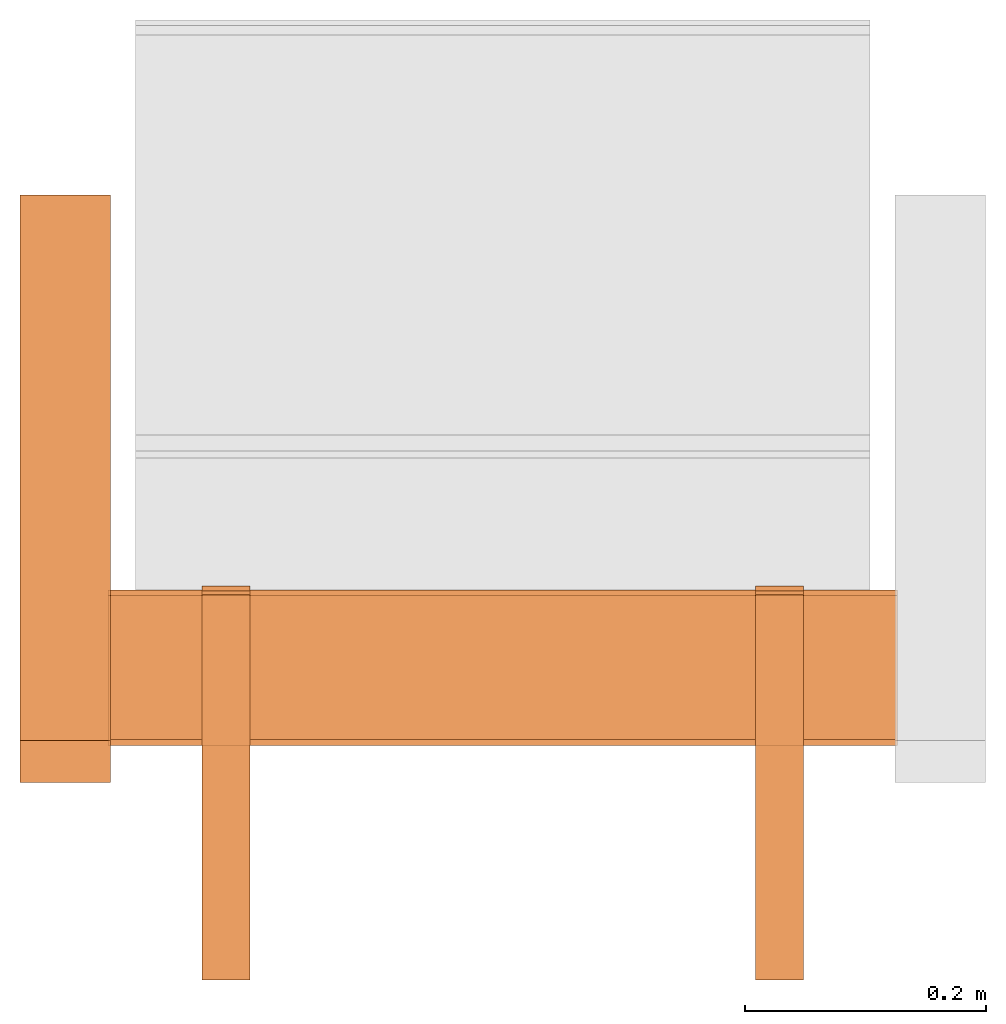
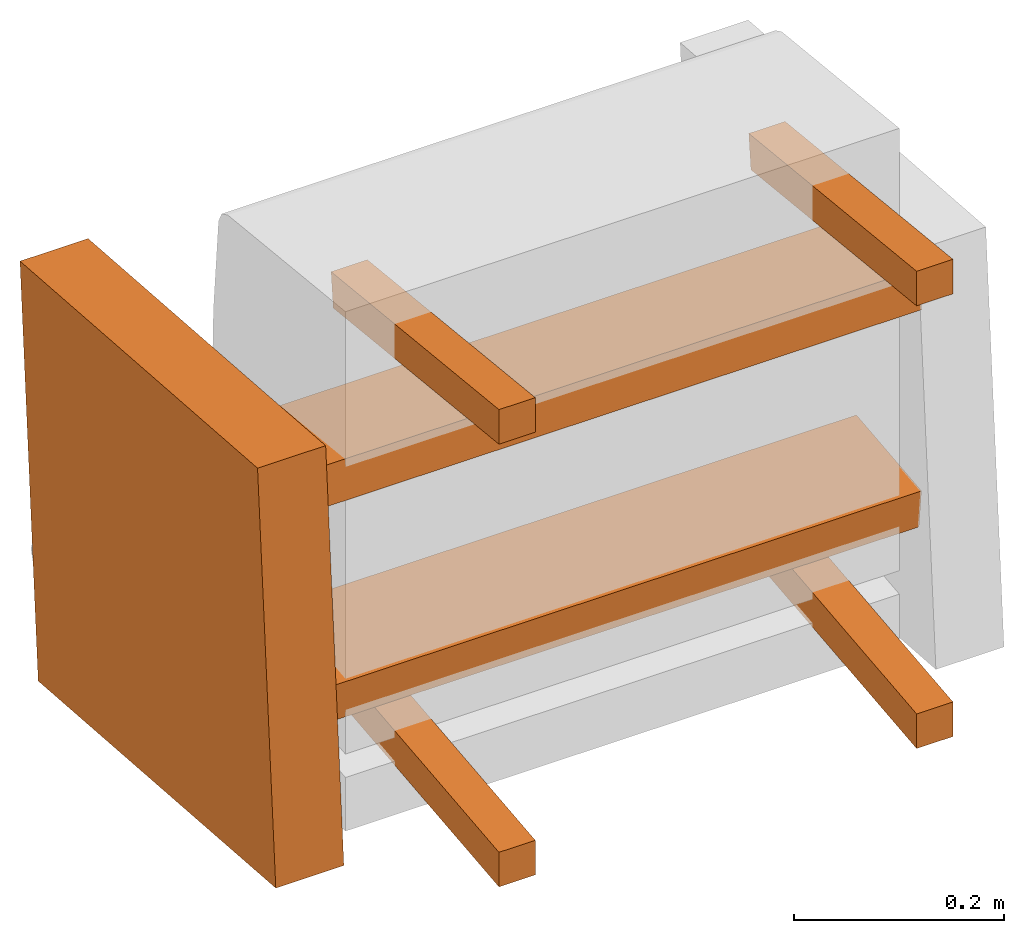
# One storey, part 2 of 2: 7 proxies, 1 element without a shape of its own.
"""IFC2X3 building model written with IfcOpenShell, lengths in metres."""

from ifc_helpers import new_model, si_unit, direction, origin_with_axes, place, context, project, spatial, faceted_brep, source, transform, mapped, element, aggregate, save


model = new_model("IFC2X3")

# Units and contexts
model_context = context("Model", 3, precision=1e-06, world=origin_with_axes(), true_north=direction((0.0, 1.0, 0.0)))
ifc_project = project(units=[si_unit("LENGTHUNIT", "METRE"), si_unit("AREAUNIT", "SQUARE_METRE"), si_unit("VOLUMEUNIT", "CUBIC_METRE")], contexts=[model_context])

# Site, building, storey
site_placement = place(None, origin_with_axes())
site = spatial("IfcSite", under=ifc_project, at=site_placement, CompositionType="ELEMENT")
building_placement = place(site_placement, origin_with_axes())
building = spatial("IfcBuilding", under=site, at=building_placement, Name="Default Building", CompositionType="ELEMENT")
storey_placement = place(building_placement, origin_with_axes())
storey = spatial("IfcBuildingStorey", under=building, at=storey_placement, Name="Default Storey", CompositionType="ELEMENT", Elevation=0.0)

# Assembly, proxies
assembly_placement = place(storey_placement, origin_with_axes())
assembly = element("IfcElementAssembly", 1, at=assembly_placement, inside=storey, Name="H-04-063-A_1-seater", ObjectType="H-04-063-A_1-seater", AssemblyPlace="NOTDEFINED", PredefinedType="NOTDEFINED")
shared_shape_1 = source(origin_with_axes(), model_context, "Body", "Brep", [
    faceted_brep([(-0.4009999930858612, -0.10968510061502457, 0.10816138237714767), (-0.4009999930858612, 0.34343305230140686, 0.07448611408472061), (-0.4009999930858612, -0.144450843334198, -0.3596296012401581), (-0.4009999930858612, -0.144450843334198, -0.3596296012401581), (-0.4009999930858612, 0.34343305230140686, 0.07448611408472061), (-0.4009999930858612, 0.30866730213165283, -0.39330488443374634), (-0.32600000500679016, -0.10968510061502457, 0.10816138237714767), (-0.4009999930858612, -0.10968510061502457, 0.10816138237714767), (-0.32600000500679016, -0.144450843334198, -0.3596296012401581), (-0.32600000500679016, -0.144450843334198, -0.3596296012401581), (-0.4009999930858612, -0.10968510061502457, 0.10816138237714767), (-0.4009999930858612, -0.144450843334198, -0.3596296012401581), (-0.32600000500679016, 0.34343305230140686, 0.07448611408472061), (-0.32600000500679016, -0.10968510061502457, 0.10816138237714767), (-0.32600000500679016, 0.30866730213165283, -0.39330488443374634), (-0.32600000500679016, 0.30866730213165283, -0.39330488443374634), (-0.32600000500679016, -0.10968510061502457, 0.10816138237714767), (-0.32600000500679016, -0.144450843334198, -0.3596296012401581), (-0.4009999930858612, 0.34343305230140686, 0.07448611408472061), (-0.32600000500679016, 0.34343305230140686, 0.07448611408472061), (-0.4009999930858612, 0.30866730213165283, -0.39330488443374634), (-0.4009999930858612, 0.30866730213165283, -0.39330488443374634), (-0.32600000500679016, 0.34343305230140686, 0.07448611408472061), (-0.32600000500679016, 0.30866730213165283, -0.39330488443374634), (-0.32600000500679016, -0.10968510061502457, 0.10816138237714767), (-0.32600000500679016, 0.34343305230140686, 0.07448611408472061), (-0.4009999930858612, -0.10968510061502457, 0.10816138237714767), (-0.4009999930858612, -0.10968510061502457, 0.10816138237714767), (-0.32600000500679016, 0.34343305230140686, 0.07448611408472061), (-0.4009999930858612, 0.34343305230140686, 0.07448611408472061), (-0.32600000500679016, 0.30866730213165283, -0.39330488443374634), (-0.32600000500679016, -0.144450843334198, -0.3596296012401581), (-0.4009999930858612, 0.30866730213165283, -0.39330488443374634), (-0.4009999930858612, 0.30866730213165283, -0.39330488443374634), (-0.32600000500679016, -0.144450843334198, -0.3596296012401581), (-0.4009999930858612, -0.144450843334198, -0.3596296012401581)], [[[0, 1, 2]], [[3, 4, 5]], [[6, 7, 8]], [[9, 10, 11]], [[12, 13, 14]], [[15, 16, 17]], [[18, 19, 20]], [[21, 22, 23]], [[24, 25, 26]], [[27, 28, 29]], [[30, 31, 32]], [[33, 34, 35]]]),
])
proxy_1_placement = place(assembly_placement, origin_with_axes())
proxy_1 = element("IfcBuildingElementProxy", 2, at=proxy_1_placement, Name="4", ObjectType="4", CompositionType="ELEMENT", context=model_context, shape_type="MappedRepresentation", body=[
    mapped(shared_shape_1, transform((0.0, 0.0, 0.0), scale=1.0)),
])
shared_shape_2 = source(origin_with_axes(), model_context, "Body", "Brep", [
    faceted_brep([(0.32800009846687317, -0.11368481069803238, -0.17104563117027283), (0.32800009846687317, 0.010630584321916103, -0.1579795628786087), (-0.328000009059906, -0.11368497461080551, -0.17104408144950867), (-0.328000009059906, -0.11368497461080551, -0.17104408144950867), (0.32800009846687317, 0.010630584321916103, -0.1579795628786087), (-0.328000009059906, 0.010630421340465546, -0.15797801315784454), (0.328000009059906, -0.10898102074861526, -0.21579918265342712), (0.32800009846687317, -0.11368481069803238, -0.17104563117027283), (-0.32800009846687317, -0.1089811846613884, -0.21579763293266296), (-0.32800009846687317, -0.1089811846613884, -0.21579763293266296), (0.32800009846687317, -0.11368481069803238, -0.17104563117027283), (-0.328000009059906, -0.11368497461080551, -0.17104408144950867), (0.328000009059906, 0.015334372408688068, -0.202733114361763), (0.328000009059906, -0.10898102074861526, -0.21579918265342712), (-0.32800009846687317, 0.01533420942723751, -0.20273156464099884), (-0.32800009846687317, 0.01533420942723751, -0.20273156464099884), (0.328000009059906, -0.10898102074861526, -0.21579918265342712), (-0.32800009846687317, -0.1089811846613884, -0.21579763293266296), (0.32800009846687317, 0.010630584321916103, -0.1579795628786087), (0.328000009059906, 0.015334372408688068, -0.202733114361763), (-0.328000009059906, 0.010630421340465546, -0.15797801315784454), (-0.328000009059906, 0.010630421340465546, -0.15797801315784454), (0.328000009059906, 0.015334372408688068, -0.202733114361763), (-0.32800009846687317, 0.01533420942723751, -0.20273156464099884), (0.328000009059906, -0.10898102074861526, -0.21579918265342712), (0.328000009059906, 0.015334372408688068, -0.202733114361763), (0.32800009846687317, -0.11368481069803238, -0.17104563117027283), (0.32800009846687317, -0.11368481069803238, -0.17104563117027283), (0.328000009059906, 0.015334372408688068, -0.202733114361763), (0.32800009846687317, 0.010630584321916103, -0.1579795628786087), (-0.32800009846687317, 0.01533420942723751, -0.20273156464099884), (-0.32800009846687317, -0.1089811846613884, -0.21579763293266296), (-0.328000009059906, 0.010630421340465546, -0.15797801315784454), (-0.328000009059906, 0.010630421340465546, -0.15797801315784454), (-0.32800009846687317, -0.1089811846613884, -0.21579763293266296), (-0.328000009059906, -0.11368497461080551, -0.17104408144950867)], [[[0, 1, 2]], [[3, 4, 5]], [[6, 7, 8]], [[9, 10, 11]], [[12, 13, 14]], [[15, 16, 17]], [[18, 19, 20]], [[21, 22, 23]], [[24, 25, 26]], [[27, 28, 29]], [[30, 31, 32]], [[33, 34, 35]]]),
])
proxy_2_placement = place(assembly_placement, origin_with_axes())
proxy_2 = element("IfcBuildingElementProxy", 3, at=proxy_2_placement, Name="5", ObjectType="5", CompositionType="ELEMENT", context=model_context, shape_type="MappedRepresentation", body=[
    mapped(shared_shape_2, transform((0.0, 0.0, 0.0), scale=1.0)),
])
shared_shape_3 = source(origin_with_axes(), model_context, "Body", "Brep", [
    faceted_brep([(-0.32800009846687317, -0.11368481069803238, 0.03987598419189453), (-0.32800009846687317, 0.010630584321916103, 0.02680990844964981), (0.328000009059906, -0.11368497461080551, 0.03987443074584007), (0.328000009059906, -0.11368497461080551, 0.03987443074584007), (-0.32800009846687317, 0.010630584321916103, 0.02680990844964981), (0.328000009059906, 0.010630421340465546, 0.02680835872888565), (-0.328000009059906, -0.10898102074861526, 0.08462953567504883), (-0.32800009846687317, -0.11368481069803238, 0.03987598419189453), (0.32800009846687317, -0.1089811846613884, 0.08462798595428467), (0.32800009846687317, -0.1089811846613884, 0.08462798595428467), (-0.32800009846687317, -0.11368481069803238, 0.03987598419189453), (0.328000009059906, -0.11368497461080551, 0.03987443074584007), (-0.328000009059906, 0.015334372408688068, 0.07156345993280411), (-0.328000009059906, -0.10898102074861526, 0.08462953567504883), (0.32800009846687317, 0.01533420942723751, 0.07156191021203995), (0.32800009846687317, 0.01533420942723751, 0.07156191021203995), (-0.328000009059906, -0.10898102074861526, 0.08462953567504883), (0.32800009846687317, -0.1089811846613884, 0.08462798595428467), (-0.32800009846687317, 0.010630584321916103, 0.02680990844964981), (-0.328000009059906, 0.015334372408688068, 0.07156345993280411), (0.328000009059906, 0.010630421340465546, 0.02680835872888565), (0.328000009059906, 0.010630421340465546, 0.02680835872888565), (-0.328000009059906, 0.015334372408688068, 0.07156345993280411), (0.32800009846687317, 0.01533420942723751, 0.07156191021203995), (-0.328000009059906, -0.10898102074861526, 0.08462953567504883), (-0.328000009059906, 0.015334372408688068, 0.07156345993280411), (-0.32800009846687317, -0.11368481069803238, 0.03987598419189453), (-0.32800009846687317, -0.11368481069803238, 0.03987598419189453), (-0.328000009059906, 0.015334372408688068, 0.07156345993280411), (-0.32800009846687317, 0.010630584321916103, 0.02680990844964981), (0.32800009846687317, 0.01533420942723751, 0.07156191021203995), (0.32800009846687317, -0.1089811846613884, 0.08462798595428467), (0.328000009059906, 0.010630421340465546, 0.02680835872888565), (0.328000009059906, 0.010630421340465546, 0.02680835872888565), (0.32800009846687317, -0.1089811846613884, 0.08462798595428467), (0.328000009059906, -0.11368497461080551, 0.03987443074584007)], [[[0, 1, 2]], [[3, 4, 5]], [[6, 7, 8]], [[9, 10, 11]], [[12, 13, 14]], [[15, 16, 17]], [[18, 19, 20]], [[21, 22, 23]], [[24, 25, 26]], [[27, 28, 29]], [[30, 31, 32]], [[33, 34, 35]]]),
])
proxy_3_placement = place(assembly_placement, origin_with_axes())
proxy_3 = element("IfcBuildingElementProxy", 4, at=proxy_3_placement, Name="6", ObjectType="6", CompositionType="ELEMENT", context=model_context, shape_type="MappedRepresentation", body=[
    mapped(shared_shape_3, transform((0.0, 0.0, 0.0), scale=1.0)),
])
shared_shape_4 = source(origin_with_axes(), model_context, "Body", "Brep", [
    faceted_brep([(0.25, -0.3086628317832947, -0.2712928354740143), (0.25, 0.014455263502895832, -0.23733174800872803), (0.20999999344348907, -0.3086628317832947, -0.2712928354740143), (0.20999999344348907, -0.3086628317832947, -0.2712928354740143), (0.25, 0.014455263502895832, -0.23733174800872803), (0.20999999344348907, 0.014455263502895832, -0.23733174800872803), (0.25, -0.3086628317832947, -0.31151315569877625), (0.25, -0.3086628317832947, -0.2712928354740143), (0.20999999344348907, -0.3086628317832947, -0.31151315569877625), (0.20999999344348907, -0.3086628317832947, -0.31151315569877625), (0.25, -0.3086628317832947, -0.2712928354740143), (0.20999999344348907, -0.3086628317832947, -0.2712928354740143), (0.25, 0.018636401742696762, -0.2771126329898834), (0.25, -0.3086628317832947, -0.31151315569877625), (0.20999999344348907, 0.018636401742696762, -0.2771126329898834), (0.20999999344348907, 0.018636401742696762, -0.2771126329898834), (0.25, -0.3086628317832947, -0.31151315569877625), (0.20999999344348907, -0.3086628317832947, -0.31151315569877625), (0.25, 0.014455263502895832, -0.23733174800872803), (0.25, 0.018636401742696762, -0.2771126329898834), (0.20999999344348907, 0.014455263502895832, -0.23733174800872803), (0.20999999344348907, 0.014455263502895832, -0.23733174800872803), (0.25, 0.018636401742696762, -0.2771126329898834), (0.20999999344348907, 0.018636401742696762, -0.2771126329898834), (0.25, -0.3086628317832947, -0.31151315569877625), (0.25, 0.018636401742696762, -0.2771126329898834), (0.25, -0.3086628317832947, -0.2712928354740143), (0.25, -0.3086628317832947, -0.2712928354740143), (0.25, 0.018636401742696762, -0.2771126329898834), (0.25, 0.014455263502895832, -0.23733174800872803), (0.20999999344348907, 0.018636401742696762, -0.2771126329898834), (0.20999999344348907, -0.3086628317832947, -0.31151315569877625), (0.20999999344348907, 0.014455263502895832, -0.23733174800872803), (0.20999999344348907, 0.014455263502895832, -0.23733174800872803), (0.20999999344348907, -0.3086628317832947, -0.31151315569877625), (0.20999999344348907, -0.3086628317832947, -0.2712928354740143)], [[[0, 1, 2]], [[3, 4, 5]], [[6, 7, 8]], [[9, 10, 11]], [[12, 13, 14]], [[15, 16, 17]], [[18, 19, 20]], [[21, 22, 23]], [[24, 25, 26]], [[27, 28, 29]], [[30, 31, 32]], [[33, 34, 35]]]),
])
proxy_4_placement = place(assembly_placement, origin_with_axes())
proxy_4 = element("IfcBuildingElementProxy", 5, at=proxy_4_placement, Name="7", ObjectType="7", CompositionType="ELEMENT", context=model_context, shape_type="MappedRepresentation", body=[
    mapped(shared_shape_4, transform((0.0, 0.0, 0.0), scale=1.0)),
])
shared_shape_5 = source(origin_with_axes(), model_context, "Body", "Brep", [
    faceted_brep([(-0.20999999344348907, -0.3086628317832947, -0.2712928354740143), (-0.20999999344348907, 0.014455263502895832, -0.23733174800872803), (-0.25, -0.3086628317832947, -0.2712928354740143), (-0.25, -0.3086628317832947, -0.2712928354740143), (-0.20999999344348907, 0.014455263502895832, -0.23733174800872803), (-0.25, 0.014455263502895832, -0.23733174800872803), (-0.20999999344348907, -0.3086628317832947, -0.31151315569877625), (-0.20999999344348907, -0.3086628317832947, -0.2712928354740143), (-0.25, -0.3086628317832947, -0.31151315569877625), (-0.25, -0.3086628317832947, -0.31151315569877625), (-0.20999999344348907, -0.3086628317832947, -0.2712928354740143), (-0.25, -0.3086628317832947, -0.2712928354740143), (-0.20999999344348907, 0.018636401742696762, -0.2771126329898834), (-0.20999999344348907, -0.3086628317832947, -0.31151315569877625), (-0.25, 0.018636401742696762, -0.2771126329898834), (-0.25, 0.018636401742696762, -0.2771126329898834), (-0.20999999344348907, -0.3086628317832947, -0.31151315569877625), (-0.25, -0.3086628317832947, -0.31151315569877625), (-0.20999999344348907, 0.014455263502895832, -0.23733174800872803), (-0.20999999344348907, 0.018636401742696762, -0.2771126329898834), (-0.25, 0.014455263502895832, -0.23733174800872803), (-0.25, 0.014455263502895832, -0.23733174800872803), (-0.20999999344348907, 0.018636401742696762, -0.2771126329898834), (-0.25, 0.018636401742696762, -0.2771126329898834), (-0.20999999344348907, -0.3086628317832947, -0.31151315569877625), (-0.20999999344348907, 0.018636401742696762, -0.2771126329898834), (-0.20999999344348907, -0.3086628317832947, -0.2712928354740143), (-0.20999999344348907, -0.3086628317832947, -0.2712928354740143), (-0.20999999344348907, 0.018636401742696762, -0.2771126329898834), (-0.20999999344348907, 0.014455263502895832, -0.23733174800872803), (-0.25, 0.018636401742696762, -0.2771126329898834), (-0.25, -0.3086628317832947, -0.31151315569877625), (-0.25, 0.014455263502895832, -0.23733174800872803), (-0.25, 0.014455263502895832, -0.23733174800872803), (-0.25, -0.3086628317832947, -0.31151315569877625), (-0.25, -0.3086628317832947, -0.2712928354740143)], [[[0, 1, 2]], [[3, 4, 5]], [[6, 7, 8]], [[9, 10, 11]], [[12, 13, 14]], [[15, 16, 17]], [[18, 19, 20]], [[21, 22, 23]], [[24, 25, 26]], [[27, 28, 29]], [[30, 31, 32]], [[33, 34, 35]]]),
])
proxy_5_placement = place(assembly_placement, origin_with_axes())
proxy_5 = element("IfcBuildingElementProxy", 6, at=proxy_5_placement, Name="8", ObjectType="8", CompositionType="ELEMENT", context=model_context, shape_type="MappedRepresentation", body=[
    mapped(shared_shape_5, transform((0.0, 0.0, 0.0), scale=1.0)),
])
shared_shape_6 = source(origin_with_axes(), model_context, "Body", "Brep", [
    faceted_brep([(0.25, -0.3086836636066437, 0.203923761844635), (0.25, -0.3086836636066437, 0.24414409697055817), (0.20999999344348907, -0.3086836636066437, 0.203923761844635), (0.20999999344348907, -0.3086836636066437, 0.203923761844635), (0.25, -0.3086836636066437, 0.24414409697055817), (0.20999999344348907, -0.3086836636066437, 0.24414409697055817), (0.25, 0.00747277494519949, 0.17069438099861145), (0.25, -0.3086836636066437, 0.203923761844635), (0.20999999344348907, 0.00747277494519949, 0.17069438099861145), (0.20999999344348907, 0.00747277494519949, 0.17069438099861145), (0.25, -0.3086836636066437, 0.203923761844635), (0.20999999344348907, -0.3086836636066437, 0.203923761844635), (0.25, 0.011653914116322994, 0.21047525107860565), (0.25, 0.00747277494519949, 0.17069438099861145), (0.20999999344348907, 0.011653914116322994, 0.21047525107860565), (0.20999999344348907, 0.011653914116322994, 0.21047525107860565), (0.25, 0.00747277494519949, 0.17069438099861145), (0.20999999344348907, 0.00747277494519949, 0.17069438099861145), (0.25, -0.3086836636066437, 0.24414409697055817), (0.25, 0.011653914116322994, 0.21047525107860565), (0.20999999344348907, -0.3086836636066437, 0.24414409697055817), (0.20999999344348907, -0.3086836636066437, 0.24414409697055817), (0.25, 0.011653914116322994, 0.21047525107860565), (0.20999999344348907, 0.011653914116322994, 0.21047525107860565), (0.25, 0.00747277494519949, 0.17069438099861145), (0.25, 0.011653914116322994, 0.21047525107860565), (0.25, -0.3086836636066437, 0.203923761844635), (0.25, -0.3086836636066437, 0.203923761844635), (0.25, 0.011653914116322994, 0.21047525107860565), (0.25, -0.3086836636066437, 0.24414409697055817), (0.20999999344348907, 0.011653914116322994, 0.21047525107860565), (0.20999999344348907, 0.00747277494519949, 0.17069438099861145), (0.20999999344348907, -0.3086836636066437, 0.24414409697055817), (0.20999999344348907, -0.3086836636066437, 0.24414409697055817), (0.20999999344348907, 0.00747277494519949, 0.17069438099861145), (0.20999999344348907, -0.3086836636066437, 0.203923761844635)], [[[0, 1, 2]], [[3, 4, 5]], [[6, 7, 8]], [[9, 10, 11]], [[12, 13, 14]], [[15, 16, 17]], [[18, 19, 20]], [[21, 22, 23]], [[24, 25, 26]], [[27, 28, 29]], [[30, 31, 32]], [[33, 34, 35]]]),
])
proxy_6_placement = place(assembly_placement, origin_with_axes())
proxy_6 = element("IfcBuildingElementProxy", 7, at=proxy_6_placement, Name="9", ObjectType="9", CompositionType="ELEMENT", context=model_context, shape_type="MappedRepresentation", body=[
    mapped(shared_shape_6, transform((0.0, 0.0, 0.0), scale=1.0)),
])
shared_shape_7 = source(origin_with_axes(), model_context, "Body", "Brep", [
    faceted_brep([(-0.20999999344348907, -0.3086836636066437, 0.203923761844635), (-0.20999999344348907, -0.3086836636066437, 0.24414409697055817), (-0.25, -0.3086836636066437, 0.203923761844635), (-0.25, -0.3086836636066437, 0.203923761844635), (-0.20999999344348907, -0.3086836636066437, 0.24414409697055817), (-0.25, -0.3086836636066437, 0.24414409697055817), (-0.20999999344348907, 0.00747277494519949, 0.17069438099861145), (-0.20999999344348907, -0.3086836636066437, 0.203923761844635), (-0.25, 0.00747277494519949, 0.17069438099861145), (-0.25, 0.00747277494519949, 0.17069438099861145), (-0.20999999344348907, -0.3086836636066437, 0.203923761844635), (-0.25, -0.3086836636066437, 0.203923761844635), (-0.20999999344348907, 0.011653914116322994, 0.21047525107860565), (-0.20999999344348907, 0.00747277494519949, 0.17069438099861145), (-0.25, 0.011653914116322994, 0.21047525107860565), (-0.25, 0.011653914116322994, 0.21047525107860565), (-0.20999999344348907, 0.00747277494519949, 0.17069438099861145), (-0.25, 0.00747277494519949, 0.17069438099861145), (-0.20999999344348907, -0.3086836636066437, 0.24414409697055817), (-0.20999999344348907, 0.011653914116322994, 0.21047525107860565), (-0.25, -0.3086836636066437, 0.24414409697055817), (-0.25, -0.3086836636066437, 0.24414409697055817), (-0.20999999344348907, 0.011653914116322994, 0.21047525107860565), (-0.25, 0.011653914116322994, 0.21047525107860565), (-0.20999999344348907, 0.00747277494519949, 0.17069438099861145), (-0.20999999344348907, 0.011653914116322994, 0.21047525107860565), (-0.20999999344348907, -0.3086836636066437, 0.203923761844635), (-0.20999999344348907, -0.3086836636066437, 0.203923761844635), (-0.20999999344348907, 0.011653914116322994, 0.21047525107860565), (-0.20999999344348907, -0.3086836636066437, 0.24414409697055817), (-0.25, 0.011653914116322994, 0.21047525107860565), (-0.25, 0.00747277494519949, 0.17069438099861145), (-0.25, -0.3086836636066437, 0.24414409697055817), (-0.25, -0.3086836636066437, 0.24414409697055817), (-0.25, 0.00747277494519949, 0.17069438099861145), (-0.25, -0.3086836636066437, 0.203923761844635)], [[[0, 1, 2]], [[3, 4, 5]], [[6, 7, 8]], [[9, 10, 11]], [[12, 13, 14]], [[15, 16, 17]], [[18, 19, 20]], [[21, 22, 23]], [[24, 25, 26]], [[27, 28, 29]], [[30, 31, 32]], [[33, 34, 35]]]),
])
proxy_7_placement = place(assembly_placement, origin_with_axes())
proxy_7 = element("IfcBuildingElementProxy", 8, at=proxy_7_placement, Name="10", ObjectType="10", CompositionType="ELEMENT", context=model_context, shape_type="MappedRepresentation", body=[
    mapped(shared_shape_7, transform((0.0, 0.0, 0.0), scale=1.0)),
])
aggregate(assembly, [proxy_1, proxy_2, proxy_3, proxy_4, proxy_5, proxy_6, proxy_7])

save(model, "model.ifc")
